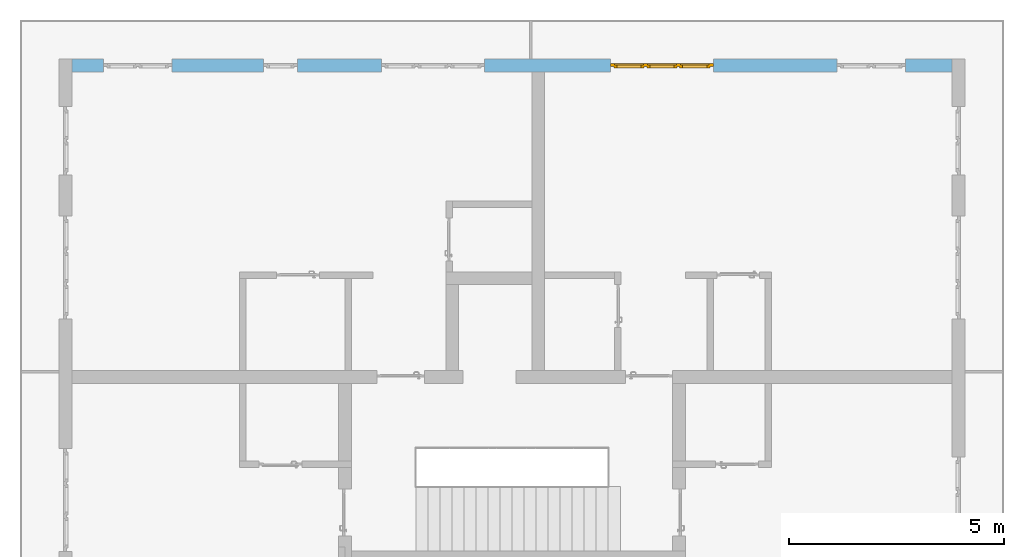
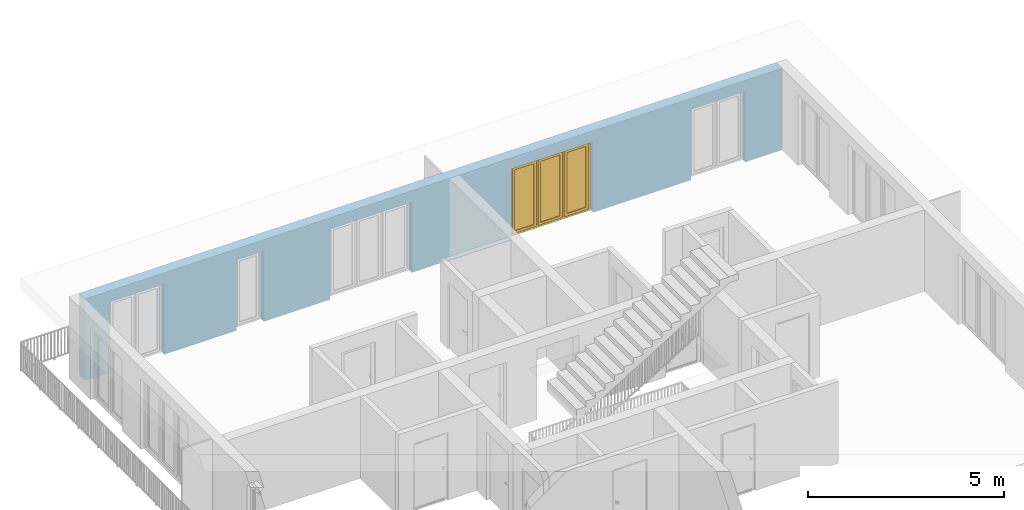
# One storey, part 23 of 48: 1 window, 5 openings, plus 1 element that does not belong to this part.
"""IFC4 building model written with IfcOpenShell, lengths in metres."""

from ifc_helpers import new_model, entity, si_unit, converted_unit, derived_unit, direction, frame, origin_with_axes, place, context, subcontext, project, spatial, polygons, source, transform, mapped, material, type_object, element, fill, save


model = new_model("IFC4")

# Units and contexts
model_context = context("Model", 3, precision=1e-05, world=origin_with_axes(), true_north=direction((0.0, 1.0)))
body_context = subcontext(model_context, "Body", "Model", "MODEL_VIEW")
ifc_project = project(units=[si_unit("LENGTHUNIT", "METRE"), si_unit("AREAUNIT", "SQUARE_METRE"), si_unit("VOLUMEUNIT", "CUBIC_METRE"), converted_unit("PLANEANGLEUNIT", "DEGREE", entity("IfcPlaneAngleMeasure", 0.0174532925199), si_unit("PLANEANGLEUNIT", "RADIAN"), dimensions=[0, 0, 0, 0, 0, 0, 0]), converted_unit("TIMEUNIT", "Year", entity("IfcTimeMeasure", 31556926.0), si_unit("TIMEUNIT", "SECOND"), dimensions=[0, 0, 1, 0, 0, 0, 0]), si_unit("MASSUNIT", "GRAM", prefix="KILO"), si_unit("THERMODYNAMICTEMPERATUREUNIT", "DEGREE_CELSIUS"), si_unit("LUMINOUSINTENSITYUNIT", "LUMEN"), si_unit("ENERGYUNIT", "JOULE", prefix="MEGA"), derived_unit("THERMALCONDUCTANCEUNIT", [(si_unit("POWERUNIT", "WATT"), 1), (si_unit("LENGTHUNIT", "METRE"), -1), (si_unit("THERMODYNAMICTEMPERATUREUNIT", "KELVIN"), -1)]), derived_unit("SPECIFICHEATCAPACITYUNIT", [(si_unit("ENERGYUNIT", "JOULE"), 1), (si_unit("MASSUNIT", "GRAM", prefix="KILO"), -1), (si_unit("THERMODYNAMICTEMPERATUREUNIT", "KELVIN"), -1)]), derived_unit("MASSDENSITYUNIT", [(si_unit("MASSUNIT", "GRAM", prefix="KILO"), 1), (si_unit("VOLUMEUNIT", "CUBIC_METRE"), -1)])], contexts=[model_context])

# Site, building, storey
site_placement = place(None, origin_with_axes())
site = spatial("IfcSite", under=ifc_project, at=site_placement, CompositionType="ELEMENT")
building_placement = place(site_placement, origin_with_axes())
building = spatial("IfcBuilding", under=site, at=building_placement, CompositionType="ELEMENT")
storey_placement = place(building_placement, frame((0.0, 0.0, 3.4), z_axis=(0.0, 0.0, 1.0), x_axis=(1.0, 0.0, 0.0)))
storey = spatial("IfcBuildingStorey", under=building, at=storey_placement, Name="1. Geschoss", CompositionType="ELEMENT", Elevation=3.4)

# Wall, openings, window
ifc_material = material()
wall_type = type_object("IfcWallType", Name="300", PredefinedType="NOTDEFINED")
wall_placement = place(storey_placement, frame((-11.7421993804, 8.92118776896, 0.0), z_axis=(0.0, 0.0, 1.0), x_axis=(1.0, 0.0, 0.0)))
wall = element("IfcWall", 1, at=wall_placement, inside=storey, type_object=wall_type, material=ifc_material, Name="Wand-001", PredefinedType="NOTDEFINED", context=body_context, shape_type="Tessellation", body=[
    polygons([(15.23, -0.1, 0.0), (15.23, -0.3, 0.0), (15.23, -0.3, 2.2), (15.23, 0.0, 2.2), (15.23, 0.0, 0.0), (18.102139809, 0.0, 0.0), (18.102139809, -0.3, 0.0), (18.102139809, -0.3, 2.2), (19.702139809, -0.3, 2.2), (19.702139809, -0.3, 0.0), (20.78, -0.3, 0.0), (20.78, -0.3, 2.54), (0.3, -0.3, 2.54), (0.3, -0.3, 0.0), (1.0288518641, -0.3, 0.0), (1.0288518641, -0.3, 2.2), (2.6288518641, -0.3, 2.2), (2.6288518641, -0.3, 0.0), (4.75, -0.3, 0.0), (4.75, -0.3, 2.2), (5.55, -0.3, 2.2), (5.55, -0.3, 0.0), (7.50089858046, -0.3, 0.0), (7.50089858046, -0.3, 2.2), (9.90089858046, -0.3, 2.2), (9.90089858046, -0.3, 0.0), (12.83, -0.3, 0.0), (12.83, -0.3, 2.2), (12.83, 0.0, 2.2), (12.83, 0.0, 0.0), (9.90089858046, 0.0, 0.0), (9.90089858046, 0.0, 2.2), (7.50089858046, 0.0, 2.2), (7.50089858046, 0.0, 0.0), (5.55, 0.0, 0.0), (5.55, 0.0, 2.2), (4.75, 0.0, 2.2), (4.75, 0.0, 0.0), (2.6288518641, 0.0, 0.0), (2.6288518641, 0.0, 2.2), (1.0288518641, 0.0, 2.2), (1.0288518641, 0.0, 0.0), (0.3, 0.0, 0.0), (0.3, 0.0, 2.54), (20.78, 0.0, 2.54), (20.78, 0.0, 0.0), (19.702139809, 0.0, 0.0), (19.702139809, 0.0, 2.2), (18.102139809, 0.0, 2.2), (12.83, -0.1, 0.0)], [[[1, 2, 3, 4, 5]], [[2, 1, 5, 6, 7]], [[3, 2, 7, 8, 9, 10, 11, 12, 13, 14, 15, 16, 17, 18, 19, 20, 21, 22, 23, 24, 25, 26, 27, 28]], [[4, 3, 28, 29]], [[6, 5, 4, 29, 30, 31, 32, 33, 34, 35, 36, 37, 38, 39, 40, 41, 42, 43, 44, 45, 46, 47, 48, 49]], [[6, 49, 8, 7]], [[8, 49, 48, 9]], [[48, 47, 10, 9]], [[46, 11, 10, 47]], [[12, 11, 46, 45]], [[45, 44, 13, 12]], [[44, 43, 14, 13]], [[15, 14, 43, 42]], [[16, 15, 42, 41]], [[40, 17, 16, 41]], [[18, 17, 40, 39]], [[19, 18, 39, 38]], [[20, 19, 38, 37]], [[36, 21, 20, 37]], [[22, 21, 36, 35]], [[22, 35, 34, 23]], [[34, 33, 24, 23]], [[24, 33, 32, 25]], [[32, 31, 26, 25]], [[50, 27, 26, 31, 30]], [[28, 27, 50, 30, 29]]], closed=True),
])
opening_1_placement = place(wall_placement, frame((1.8288518641, 0.0, 0.0), z_axis=(0.0, 0.0, 1.0), x_axis=(1.0, 0.0, 0.0)))
element("IfcOpeningElement", 2, at=opening_1_placement, cuts=wall, Name="Fenster-001", context=body_context, identifier="Reference", shape_type="Tessellation", body=[
    polygons([(-0.8, -0.1, 0.0), (-0.8, -0.1, 2.2), (-0.8, 0.000999999999998, 2.2), (-0.8, 0.000999999999998, 0.0), (-0.8, -0.301, 0.0), (-0.8, -0.301, 2.2), (0.8, -0.1, 2.2), (0.8, 0.000999999999999, 2.2), (0.8, -0.301, 2.2), (0.8, 0.000999999999999, 0.0), (0.8, -0.1, 0.0), (0.8, -0.301, 0.0)], [[[1, 2, 3, 4]], [[2, 1, 5, 6]], [[7, 8, 3, 2, 6, 9]], [[8, 10, 4, 3]], [[1, 4, 10, 11, 12, 5]], [[6, 5, 12, 9]], [[7, 11, 10, 8]], [[11, 7, 9, 12]]], closed=True),
])
opening_2_placement = place(wall_placement, frame((8.70089858046, 0.0, 0.0), z_axis=(0.0, 0.0, 1.0), x_axis=(1.0, 0.0, 0.0)))
element("IfcOpeningElement", 3, at=opening_2_placement, cuts=wall, Name="Fenster-002", context=body_context, identifier="Reference", shape_type="Tessellation", body=[
    polygons([(-1.2, -0.1, 0.0), (-1.2, -0.1, 2.2), (-1.2, 0.000999999999999, 2.2), (-1.2, 0.000999999999999, 0.0), (-1.2, -0.301, 0.0), (-1.2, -0.301, 2.2), (1.2, -0.1, 2.2), (1.2, 0.001, 2.2), (1.2, -0.301, 2.2), (1.2, 0.001, 0.0), (1.2, -0.1, 0.0), (1.2, -0.301, 0.0)], [[[1, 2, 3, 4]], [[2, 1, 5, 6]], [[7, 8, 3, 2, 6, 9]], [[8, 10, 4, 3]], [[1, 4, 10, 11, 12, 5]], [[6, 5, 12, 9]], [[7, 11, 10, 8]], [[11, 7, 9, 12]]], closed=True),
])
opening_3_placement = place(wall_placement, frame((5.15, 0.0, 0.0), z_axis=(0.0, 0.0, 1.0), x_axis=(1.0, 0.0, 0.0)))
element("IfcOpeningElement", 4, at=opening_3_placement, cuts=wall, Name="Fenster-003", context=body_context, identifier="Reference", shape_type="Tessellation", body=[
    polygons([(-0.4, -0.1, 0.0), (-0.4, -0.1, 2.2), (-0.4, 0.001, 2.2), (-0.4, 0.001, 0.0), (-0.4, -0.301, 0.0), (-0.4, -0.301, 2.2), (0.4, -0.1, 2.2), (0.4, 0.001, 2.2), (0.4, -0.301, 2.2), (0.4, 0.001, 0.0), (0.4, -0.1, 0.0), (0.4, -0.301, 0.0)], [[[1, 2, 3, 4]], [[2, 1, 5, 6]], [[7, 8, 3, 2, 6, 9]], [[8, 10, 4, 3]], [[1, 4, 10, 11, 12, 5]], [[6, 5, 12, 9]], [[7, 11, 10, 8]], [[11, 7, 9, 12]]], closed=True),
])
opening_4_placement = place(wall_placement, frame((18.902139809, 0.0, 0.0), z_axis=(0.0, 0.0, 1.0), x_axis=(1.0, 0.0, 0.0)))
element("IfcOpeningElement", 5, at=opening_4_placement, cuts=wall, Name="Fenster-001", context=body_context, identifier="Reference", shape_type="Tessellation", body=[
    polygons([(-0.8, -0.1, 0.0), (-0.8, -0.1, 2.2), (-0.8, 0.001, 2.2), (-0.8, 0.001, 0.0), (-0.8, -0.301, 0.0), (-0.8, -0.301, 2.2), (0.8, -0.1, 2.2), (0.8, 0.001, 2.2), (0.8, -0.301, 2.2), (0.8, 0.001, 0.0), (0.8, -0.1, 0.0), (0.8, -0.301, 0.0)], [[[1, 2, 3, 4]], [[2, 1, 5, 6]], [[7, 8, 3, 2, 6, 9]], [[8, 10, 4, 3]], [[1, 4, 10, 11, 12, 5]], [[6, 5, 12, 9]], [[7, 11, 10, 8]], [[11, 7, 9, 12]]], closed=True),
])
opening_5_placement = place(wall_placement, frame((14.03, 0.0, 0.0), z_axis=(0.0, 0.0, 1.0), x_axis=(1.0, 0.0, 0.0)))
opening_5 = element("IfcOpeningElement", 6, at=opening_5_placement, cuts=wall, Name="Fenster-002", context=body_context, identifier="Reference", shape_type="Tessellation", body=[
    polygons([(-1.2, -0.1, 0.0), (-1.2, -0.1, 2.2), (-1.2, 0.001, 2.2), (-1.2, 0.001, 0.0), (-1.2, -0.301, 0.0), (-1.2, -0.301, 2.2), (1.2, -0.1, 2.2), (1.2, 0.001, 2.2), (1.2, -0.301, 2.2), (1.2, 0.001, 0.0), (1.2, -0.1, 0.0), (1.2, -0.301, 0.0)], [[[1, 2, 3, 4]], [[2, 1, 5, 6]], [[7, 8, 3, 2, 6, 9]], [[8, 10, 4, 3]], [[1, 4, 10, 11, 12, 5]], [[6, 5, 12, 9]], [[7, 11, 10, 8]], [[11, 7, 9, 12]]], closed=True),
])
window_type = type_object("IfcWindowType", Name="3-1+1+1 26", PartitioningType="TRIPLE_PANEL_VERTICAL", PredefinedType="WINDOW")
shared_shape = source(origin_with_axes(), body_context, "Body", "Tessellation", [
    polygons([(-1.2, -0.07, 0.0), (-1.2, 0.0, 0.0), (-1.1, 0.0, 0.1), (-1.1, -0.07, 0.1), (-1.2, -0.07, 2.2), (-1.2, 0.0, 2.2), (-1.1, 0.0, 2.1), (-1.1, -0.07, 2.1)], [[[1, 2, 3, 4]], [[5, 6, 2, 1]], [[2, 6, 7, 3]], [[4, 3, 7, 8]], [[1, 4, 8, 5]], [[8, 7, 6, 5]]], closed=True),
    polygons([(1.2, -0.07, 0.0), (1.2, 0.0, 0.0), (1.2, 0.0, 2.2), (1.2, -0.07, 2.2), (1.1, -0.07, 0.1), (1.1, 0.0, 0.1), (1.1, 0.0, 2.1), (1.1, -0.07, 2.1)], [[[1, 2, 3, 4]], [[5, 6, 2, 1]], [[2, 6, 7, 3]], [[4, 3, 7, 8]], [[1, 4, 8, 5]], [[8, 7, 6, 5]]], closed=True),
    polygons([(-1.2, -0.07, 0.0), (-1.2, 0.0, 0.0), (1.2, 0.0, 0.0), (1.2, -0.07, 0.0), (-1.1, -0.07, 0.1), (-1.1, 0.0, 0.1), (-0.433333333333, 0.0, 0.1), (-0.333333333333, 0.0, 0.1), (0.333333333333, 0.0, 0.1), (0.433333333333, 0.0, 0.1), (1.1, 0.0, 0.1), (1.1, -0.07, 0.1), (0.433333333333, -0.07, 0.1), (0.333333333333, -0.07, 0.1), (-0.333333333333, -0.07, 0.1), (-0.433333333333, -0.07, 0.1)], [[[1, 2, 3, 4]], [[5, 6, 2, 1]], [[2, 6, 7, 8, 9, 10, 11, 3]], [[4, 3, 11, 12]], [[1, 4, 12, 13, 14, 15, 16, 5]], [[16, 7, 6, 5]], [[15, 8, 7, 16]], [[14, 9, 8, 15]], [[13, 10, 9, 14]], [[12, 11, 10, 13]]], closed=True),
    polygons([(-1.2, -0.07, 2.2), (-1.2, 0.0, 2.2), (-1.1, 0.0, 2.1), (-1.1, -0.07, 2.1), (1.2, -0.07, 2.2), (1.2, 0.0, 2.2), (1.1, 0.0, 2.1), (0.433333333333, 0.0, 2.1), (0.333333333333, 0.0, 2.1), (-0.333333333333, 0.0, 2.1), (-0.433333333333, 0.0, 2.1), (-0.433333333333, -0.07, 2.1), (-0.333333333333, -0.07, 2.1), (0.333333333333, -0.07, 2.1), (0.433333333333, -0.07, 2.1), (1.1, -0.07, 2.1)], [[[1, 2, 3, 4]], [[5, 6, 2, 1]], [[2, 6, 7, 8, 9, 10, 11, 3]], [[4, 3, 11, 12]], [[1, 4, 12, 13, 14, 15, 16, 5]], [[16, 7, 6, 5]], [[15, 8, 7, 16]], [[14, 9, 8, 15]], [[13, 10, 9, 14]], [[12, 11, 10, 13]]], closed=True),
    polygons([(0.333333333333, -0.07, 0.1), (0.333333333333, 0.0, 0.1), (0.433333333333, 0.0, 0.1), (0.433333333333, -0.07, 0.1), (0.333333333333, -0.07, 2.1), (0.333333333333, 0.0, 2.1), (0.433333333333, 0.0, 2.1), (0.433333333333, -0.07, 2.1)], [[[1, 2, 3, 4]], [[5, 6, 2, 1]], [[2, 6, 7, 3]], [[4, 3, 7, 8]], [[1, 4, 8, 5]], [[8, 7, 6, 5]]], closed=True),
    polygons([(-0.433333333333, -0.07, 0.1), (-0.433333333333, 0.0, 0.1), (-0.333333333333, 0.0, 0.1), (-0.333333333333, -0.07, 0.1), (-0.433333333333, -0.07, 2.1), (-0.433333333333, 0.0, 2.1), (-0.333333333333, 0.0, 2.1), (-0.333333333333, -0.07, 2.1)], [[[1, 2, 3, 4]], [[5, 6, 2, 1]], [[2, 6, 7, 3]], [[4, 3, 7, 8]], [[1, 4, 8, 5]], [[8, 7, 6, 5]]], closed=True),
    polygons([(-1.12, 0.0, 0.08), (-1.12, 0.03, 0.08), (-1.05, 0.03, 0.15), (-1.05, 0.0, 0.15), (-1.12, 0.0, 2.12), (-1.12, 0.03, 2.12), (-1.05, 0.03, 2.05), (-1.05, 0.0, 2.05)], [[[1, 2, 3, 4]], [[5, 6, 2, 1]], [[2, 6, 7, 3]], [[4, 3, 7, 8]], [[1, 4, 8, 5]], [[8, 7, 6, 5]]], closed=True),
    polygons([(-0.413333333333, 0.0, 0.08), (-0.483333333333, 0.0, 0.15), (-0.483333333333, 0.03, 0.15), (-0.413333333333, 0.03, 0.08), (-0.413333333333, 0.0, 2.12), (-0.483333333333, 0.0, 2.05), (-0.483333333333, 0.03, 2.05), (-0.413333333333, 0.03, 2.12)], [[[1, 2, 3, 4]], [[1, 5, 6, 2]], [[2, 6, 7, 3]], [[4, 3, 7, 8]], [[5, 1, 4, 8]], [[6, 5, 8, 7]]], closed=True),
    polygons([(-1.12, 0.0, 0.08), (-1.12, 0.03, 0.08), (-0.413333333333, 0.03, 0.08), (-0.413333333333, 0.0, 0.08), (-1.05, 0.0, 0.15), (-1.05, 0.03, 0.15), (-0.483333333333, 0.03, 0.15), (-0.483333333333, 0.0, 0.15)], [[[1, 2, 3, 4]], [[5, 6, 2, 1]], [[2, 6, 7, 3]], [[4, 3, 7, 8]], [[1, 4, 8, 5]], [[8, 7, 6, 5]]], closed=True),
    polygons([(-1.12, 0.0, 2.12), (-0.413333333333, 0.0, 2.12), (-0.413333333333, 0.03, 2.12), (-1.12, 0.03, 2.12), (-1.05, 0.0, 2.05), (-0.483333333333, 0.0, 2.05), (-0.483333333333, 0.03, 2.05), (-1.05, 0.03, 2.05)], [[[1, 2, 3, 4]], [[1, 5, 6, 2]], [[2, 6, 7, 3]], [[4, 3, 7, 8]], [[5, 1, 4, 8]], [[6, 5, 8, 7]]], closed=True),
    polygons([(-1.1, -0.03, 0.1), (-1.1, 0.0, 0.1), (-1.05, 0.0, 0.15), (-1.05, -0.03, 0.15), (-1.1, -0.03, 2.1), (-1.1, 0.0, 2.1), (-1.05, 0.0, 2.05), (-1.05, -0.03, 2.05)], [[[1, 2, 3, 4]], [[5, 6, 2, 1]], [[2, 6, 7, 3]], [[4, 3, 7, 8]], [[1, 4, 8, 5]], [[8, 7, 6, 5]]], closed=True),
    polygons([(-0.433333333333, -0.03, 0.1), (-0.483333333333, -0.03, 0.15), (-0.483333333333, 0.0, 0.15), (-0.433333333333, 0.0, 0.1), (-0.433333333333, -0.03, 2.1), (-0.483333333333, -0.03, 2.05), (-0.483333333333, 0.0, 2.05), (-0.433333333333, 0.0, 2.1)], [[[1, 2, 3, 4]], [[1, 5, 6, 2]], [[2, 6, 7, 3]], [[4, 3, 7, 8]], [[5, 1, 4, 8]], [[6, 5, 8, 7]]], closed=True),
    polygons([(-1.1, -0.03, 0.1), (-1.1, 0.0, 0.1), (-0.433333333333, 0.0, 0.1), (-0.433333333333, -0.03, 0.1), (-1.05, -0.03, 0.15), (-1.05, 0.0, 0.15), (-0.483333333333, 0.0, 0.15), (-0.483333333333, -0.03, 0.15)], [[[1, 2, 3, 4]], [[5, 6, 2, 1]], [[2, 6, 7, 3]], [[4, 3, 7, 8]], [[1, 4, 8, 5]], [[8, 7, 6, 5]]], closed=True),
    polygons([(-1.1, -0.03, 2.1), (-0.433333333333, -0.03, 2.1), (-0.433333333333, 0.0, 2.1), (-1.1, 0.0, 2.1), (-1.05, -0.03, 2.05), (-0.483333333333, -0.03, 2.05), (-0.483333333333, 0.0, 2.05), (-1.05, 0.0, 2.05)], [[[1, 2, 3, 4]], [[1, 5, 6, 2]], [[2, 6, 7, 3]], [[4, 3, 7, 8]], [[5, 1, 4, 8]], [[6, 5, 8, 7]]], closed=True),
    polygons([(-1.05, -0.005, 0.15), (-1.05, 0.005, 0.15), (-0.483333333333, 0.005, 0.15), (-0.483333333333, -0.005, 0.15), (-1.05, -0.005, 2.05), (-1.05, 0.005, 2.05), (-0.483333333333, 0.005, 2.05), (-0.483333333333, -0.005, 2.05)], [[[1, 2, 3, 4]], [[5, 6, 2, 1]], [[2, 6, 7, 3]], [[4, 3, 7, 8]], [[1, 4, 8, 5]], [[8, 7, 6, 5]]], closed=True),
    polygons([(-0.353333333333, 0.0, 0.08), (-0.353333333333, 0.03, 0.08), (-0.283333333333, 0.03, 0.15), (-0.283333333333, 0.0, 0.15), (-0.353333333333, 0.0, 2.12), (-0.353333333333, 0.03, 2.12), (-0.283333333333, 0.03, 2.05), (-0.283333333333, 0.0, 2.05)], [[[1, 2, 3, 4]], [[5, 6, 2, 1]], [[2, 6, 7, 3]], [[4, 3, 7, 8]], [[1, 4, 8, 5]], [[8, 7, 6, 5]]], closed=True),
    polygons([(0.353333333333, 0.0, 0.08), (0.283333333333, 0.0, 0.15), (0.283333333333, 0.03, 0.15), (0.353333333333, 0.03, 0.08), (0.353333333333, 0.0, 2.12), (0.283333333333, 0.0, 2.05), (0.283333333333, 0.03, 2.05), (0.353333333333, 0.03, 2.12)], [[[1, 2, 3, 4]], [[1, 5, 6, 2]], [[2, 6, 7, 3]], [[4, 3, 7, 8]], [[5, 1, 4, 8]], [[6, 5, 8, 7]]], closed=True),
    polygons([(-0.353333333333, 0.0, 0.08), (-0.353333333333, 0.03, 0.08), (0.353333333333, 0.03, 0.08), (0.353333333333, 0.0, 0.08), (-0.283333333333, 0.0, 0.15), (-0.283333333333, 0.03, 0.15), (0.283333333333, 0.03, 0.15), (0.283333333333, 0.0, 0.15)], [[[1, 2, 3, 4]], [[5, 6, 2, 1]], [[2, 6, 7, 3]], [[4, 3, 7, 8]], [[1, 4, 8, 5]], [[8, 7, 6, 5]]], closed=True),
    polygons([(-0.353333333333, 0.0, 2.12), (0.353333333333, 0.0, 2.12), (0.353333333333, 0.03, 2.12), (-0.353333333333, 0.03, 2.12), (-0.283333333333, 0.0, 2.05), (0.283333333333, 0.0, 2.05), (0.283333333333, 0.03, 2.05), (-0.283333333333, 0.03, 2.05)], [[[1, 2, 3, 4]], [[1, 5, 6, 2]], [[2, 6, 7, 3]], [[4, 3, 7, 8]], [[5, 1, 4, 8]], [[6, 5, 8, 7]]], closed=True),
    polygons([(-0.333333333333, -0.03, 0.1), (-0.333333333333, 0.0, 0.1), (-0.283333333333, 0.0, 0.15), (-0.283333333333, -0.03, 0.15), (-0.333333333333, -0.03, 2.1), (-0.333333333333, 0.0, 2.1), (-0.283333333333, 0.0, 2.05), (-0.283333333333, -0.03, 2.05)], [[[1, 2, 3, 4]], [[5, 6, 2, 1]], [[2, 6, 7, 3]], [[4, 3, 7, 8]], [[1, 4, 8, 5]], [[8, 7, 6, 5]]], closed=True),
    polygons([(0.333333333333, -0.03, 0.1), (0.283333333333, -0.03, 0.15), (0.283333333333, 0.0, 0.15), (0.333333333333, 0.0, 0.1), (0.333333333333, -0.03, 2.1), (0.283333333333, -0.03, 2.05), (0.283333333333, 0.0, 2.05), (0.333333333333, 0.0, 2.1)], [[[1, 2, 3, 4]], [[1, 5, 6, 2]], [[2, 6, 7, 3]], [[4, 3, 7, 8]], [[5, 1, 4, 8]], [[6, 5, 8, 7]]], closed=True),
    polygons([(-0.333333333333, -0.03, 0.1), (-0.333333333333, 0.0, 0.1), (0.333333333333, 0.0, 0.1), (0.333333333333, -0.03, 0.1), (-0.283333333333, -0.03, 0.15), (-0.283333333333, 0.0, 0.15), (0.283333333333, 0.0, 0.15), (0.283333333333, -0.03, 0.15)], [[[1, 2, 3, 4]], [[5, 6, 2, 1]], [[2, 6, 7, 3]], [[4, 3, 7, 8]], [[1, 4, 8, 5]], [[8, 7, 6, 5]]], closed=True),
    polygons([(-0.333333333333, -0.03, 2.1), (0.333333333333, -0.03, 2.1), (0.333333333333, 0.0, 2.1), (-0.333333333333, 0.0, 2.1), (-0.283333333333, -0.03, 2.05), (0.283333333333, -0.03, 2.05), (0.283333333333, 0.0, 2.05), (-0.283333333333, 0.0, 2.05)], [[[1, 2, 3, 4]], [[1, 5, 6, 2]], [[2, 6, 7, 3]], [[4, 3, 7, 8]], [[5, 1, 4, 8]], [[6, 5, 8, 7]]], closed=True),
    polygons([(-0.283333333333, -0.005, 0.15), (-0.283333333333, 0.005, 0.15), (0.283333333333, 0.005, 0.15), (0.283333333333, -0.005, 0.15), (-0.283333333333, -0.005, 2.05), (-0.283333333333, 0.005, 2.05), (0.283333333333, 0.005, 2.05), (0.283333333333, -0.005, 2.05)], [[[1, 2, 3, 4]], [[5, 6, 2, 1]], [[2, 6, 7, 3]], [[4, 3, 7, 8]], [[1, 4, 8, 5]], [[8, 7, 6, 5]]], closed=True),
    polygons([(0.413333333333, 0.0, 0.08), (0.413333333333, 0.03, 0.08), (0.483333333333, 0.03, 0.15), (0.483333333333, 0.0, 0.15), (0.413333333333, 0.0, 2.12), (0.413333333333, 0.03, 2.12), (0.483333333333, 0.03, 2.05), (0.483333333333, 0.0, 2.05)], [[[1, 2, 3, 4]], [[5, 6, 2, 1]], [[2, 6, 7, 3]], [[4, 3, 7, 8]], [[1, 4, 8, 5]], [[8, 7, 6, 5]]], closed=True),
    polygons([(1.12, 0.0, 0.08), (1.05, 0.0, 0.15), (1.05, 0.03, 0.15), (1.12, 0.03, 0.08), (1.12, 0.0, 2.12), (1.05, 0.0, 2.05), (1.05, 0.03, 2.05), (1.12, 0.03, 2.12)], [[[1, 2, 3, 4]], [[1, 5, 6, 2]], [[2, 6, 7, 3]], [[4, 3, 7, 8]], [[5, 1, 4, 8]], [[6, 5, 8, 7]]], closed=True),
    polygons([(0.413333333333, 0.0, 0.08), (0.413333333333, 0.03, 0.08), (1.12, 0.03, 0.08), (1.12, 0.0, 0.08), (0.483333333333, 0.0, 0.15), (0.483333333333, 0.03, 0.15), (1.05, 0.03, 0.15), (1.05, 0.0, 0.15)], [[[1, 2, 3, 4]], [[5, 6, 2, 1]], [[2, 6, 7, 3]], [[4, 3, 7, 8]], [[1, 4, 8, 5]], [[8, 7, 6, 5]]], closed=True),
    polygons([(0.413333333333, 0.0, 2.12), (1.12, 0.0, 2.12), (1.12, 0.03, 2.12), (0.413333333333, 0.03, 2.12), (0.483333333333, 0.0, 2.05), (1.05, 0.0, 2.05), (1.05, 0.03, 2.05), (0.483333333333, 0.03, 2.05)], [[[1, 2, 3, 4]], [[1, 5, 6, 2]], [[2, 6, 7, 3]], [[4, 3, 7, 8]], [[5, 1, 4, 8]], [[6, 5, 8, 7]]], closed=True),
    polygons([(0.433333333333, -0.03, 0.1), (0.433333333333, 0.0, 0.1), (0.483333333333, 0.0, 0.15), (0.483333333333, -0.03, 0.15), (0.433333333333, -0.03, 2.1), (0.433333333333, 0.0, 2.1), (0.483333333333, 0.0, 2.05), (0.483333333333, -0.03, 2.05)], [[[1, 2, 3, 4]], [[5, 6, 2, 1]], [[2, 6, 7, 3]], [[4, 3, 7, 8]], [[1, 4, 8, 5]], [[8, 7, 6, 5]]], closed=True),
    polygons([(1.1, -0.03, 0.1), (1.05, -0.03, 0.15), (1.05, 0.0, 0.15), (1.1, 0.0, 0.1), (1.1, -0.03, 2.1), (1.05, -0.03, 2.05), (1.05, 0.0, 2.05), (1.1, 0.0, 2.1)], [[[1, 2, 3, 4]], [[1, 5, 6, 2]], [[2, 6, 7, 3]], [[4, 3, 7, 8]], [[5, 1, 4, 8]], [[6, 5, 8, 7]]], closed=True),
    polygons([(0.433333333333, -0.03, 0.1), (0.433333333333, 0.0, 0.1), (1.1, 0.0, 0.1), (1.1, -0.03, 0.1), (0.483333333333, -0.03, 0.15), (0.483333333333, 0.0, 0.15), (1.05, 0.0, 0.15), (1.05, -0.03, 0.15)], [[[1, 2, 3, 4]], [[5, 6, 2, 1]], [[2, 6, 7, 3]], [[4, 3, 7, 8]], [[1, 4, 8, 5]], [[8, 7, 6, 5]]], closed=True),
    polygons([(0.433333333333, -0.03, 2.1), (1.1, -0.03, 2.1), (1.1, 0.0, 2.1), (0.433333333333, 0.0, 2.1), (0.483333333333, -0.03, 2.05), (1.05, -0.03, 2.05), (1.05, 0.0, 2.05), (0.483333333333, 0.0, 2.05)], [[[1, 2, 3, 4]], [[1, 5, 6, 2]], [[2, 6, 7, 3]], [[4, 3, 7, 8]], [[5, 1, 4, 8]], [[6, 5, 8, 7]]], closed=True),
    polygons([(0.483333333333, -0.005, 0.15), (0.483333333333, 0.005, 0.15), (1.05, 0.005, 0.15), (1.05, -0.005, 0.15), (0.483333333333, -0.005, 2.05), (0.483333333333, 0.005, 2.05), (1.05, 0.005, 2.05), (1.05, -0.005, 2.05)], [[[1, 2, 3, 4]], [[5, 6, 2, 1]], [[2, 6, 7, 3]], [[4, 3, 7, 8]], [[1, 4, 8, 5]], [[8, 7, 6, 5]]], closed=True),
])
window_placement = place(opening_5_placement, frame((1.2, 0.0, 0.0), z_axis=(0.0, 0.0, 1.0), x_axis=(-1.0, 0.0, 0.0)))
window = element("IfcWindow", 7, at=window_placement, inside=storey, type_object=window_type, Name="Fenster-002", OverallHeight=2.2, OverallWidth=2.4, PredefinedType="WINDOW", context=body_context, shape_type="MappedRepresentation", body=[
    mapped(shared_shape, transform((1.2, 0.17, 0.0))),
])
fill(opening_5, window)

save(model, "model.ifc")
